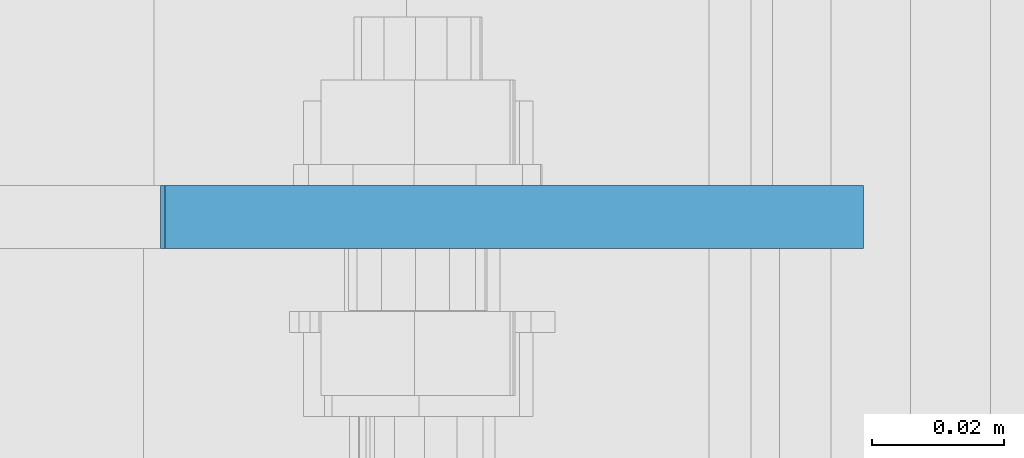
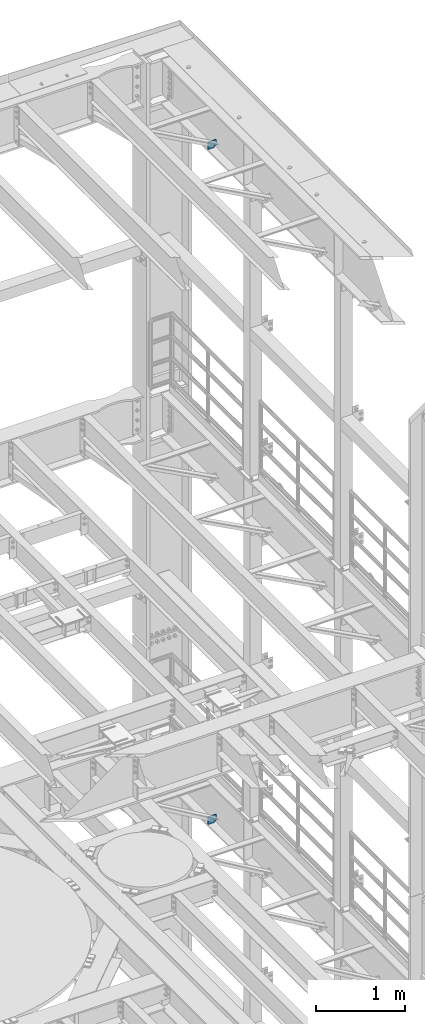
# One storey, part 1805 of 1876: 2 plates, 2 elements without a shape of their own.
"""IFC2X3 building model written with IfcOpenShell, lengths in millimetres."""

from ifc_helpers import new_model, si_unit, frame, origin_with_axes, place, context, subcontext, project, spatial, faceted_brep, material, type_object, element, aggregate, save


model = new_model("IFC2X3")

# Units and contexts
model_context = context("Model", 3, precision=1e-05, world=origin_with_axes())
body_context = subcontext(model_context, "Body", "Model", "MODEL_VIEW")
ifc_project = project(units=[si_unit("LENGTHUNIT", "METRE", prefix="MILLI"), si_unit("AREAUNIT", "SQUARE_METRE"), si_unit("VOLUMEUNIT", "CUBIC_METRE"), si_unit("MASSUNIT", "GRAM", prefix="KILO"), si_unit("TIMEUNIT", "SECOND"), si_unit("PLANEANGLEUNIT", "RADIAN"), si_unit("SOLIDANGLEUNIT", "STERADIAN"), si_unit("THERMODYNAMICTEMPERATUREUNIT", "DEGREE_CELSIUS"), si_unit("LUMINOUSINTENSITYUNIT", "LUMEN")], contexts=[model_context])

# Site, building, storey
site_placement = place(None, origin_with_axes())
site = spatial("IfcSite", under=ifc_project, at=site_placement, CompositionType="ELEMENT")
building_placement = place(site_placement, origin_with_axes())
building = spatial("IfcBuilding", under=site, at=building_placement, Name="Undefined", CompositionType="ELEMENT")
storey_placement = place(building_placement, origin_with_axes())
storey = spatial("IfcBuildingStorey", under=building, at=storey_placement, Name="Undefined", CompositionType="ELEMENT", Elevation=0.0)

# Assembly, plate
assembly_1_placement = place(storey_placement, origin_with_axes())
assembly_1 = element("IfcElementAssembly", 1, at=assembly_1_placement, inside=storey, Name="BEAM", AssemblyPlace="NOTDEFINED", PredefinedType="RIGID_FRAME")
ifc_material = material(Name="STEEL/A36")
plate_type_1 = type_object("IfcPlateType", PredefinedType="NOTDEFINED")
plate_1_placement = place(assembly_1_placement, frame((7612.85625, 12492.0375, 21958.3), z_axis=(0.0, 0.0, 1.0), x_axis=(-1.0, 0.0, 0.0)))
plate_1 = element("IfcPlate", 2, at=plate_1_placement, type_object=plate_type_1, material=ifc_material, Name="PLATE", context=body_context, shape_type="Brep", body=[
    faceted_brep([(-9.76996261670138e-14, -4.76250000000073, 31.75), (-3.4106151360902e-06, -4.76249999999982, 104.420860290527), (-3.4106151360902e-06, 4.76249999999982, 104.420860290527), (-9.76996261670138e-14, 4.76250000000073, 31.75), (105.552177429199, -4.76249999999982, 104.420860290527), (105.552177429199, 4.76249999999982, 104.420860290527), (105.552177429199, -4.76249999999982, 0.0), (105.552177429199, 4.76249999999982, 0.0), (31.75, -4.76250000000073, 0.0), (31.75, 4.76250000000073, 0.0)], [[[0, 1, 2, 3]], [[1, 4, 5, 2]], [[4, 6, 7, 5]], [[6, 8, 9, 7]], [[8, 0, 3, 9]], [[5, 7, 9, 3, 2]], [[8, 6, 4, 1, 0]]]),
])
aggregate(assembly_1, [plate_1])

assembly_2_placement = place(storey_placement, origin_with_axes())
assembly_2 = element("IfcElementAssembly", 3, at=assembly_2_placement, inside=storey, Name="BEAM", AssemblyPlace="NOTDEFINED", PredefinedType="RIGID_FRAME")
plate_type_2 = type_object("IfcPlateType", PredefinedType="NOTDEFINED")
plate_2_placement = place(assembly_2_placement, frame((7612.85625021727, 12492.0375, 12819.726415621), z_axis=(0.0, 0.0, -1.0), x_axis=(-1.0, 0.0, 0.0)))
plate_2 = element("IfcPlate", 4, at=plate_2_placement, type_object=plate_type_2, material=ifc_material, Name="PLATE", context=body_context, shape_type="Brep", body=[
    faceted_brep([(0.0, -4.76249999999982, 0.0), (-3.57139560946962e-06, -4.76249999999982, 81.6264114379865), (-3.57139560946962e-06, 4.76249999999982, 81.6264114379865), (0.0, 4.76249999999982, 0.0), (25.3999958038776, -4.76249999999982, 107.026412963854), (25.3999958038776, 4.76249999999982, 107.026412963854), (106.188095092818, -4.76249999999982, 107.02641296382), (106.188095092818, 4.76249999999982, 107.02641296382), (106.188095092773, -4.76249999999982, -7.27595761418343e-11), (106.188095092773, 4.76249999999982, -7.27595761418343e-11)], [[[0, 1, 2, 3]], [[1, 4, 5, 2]], [[4, 6, 7, 5]], [[6, 8, 9, 7]], [[8, 0, 3, 9]], [[5, 7, 9, 3, 2]], [[8, 6, 4, 1, 0]]]),
])
aggregate(assembly_2, [plate_2])

save(model, "model.ifc")
